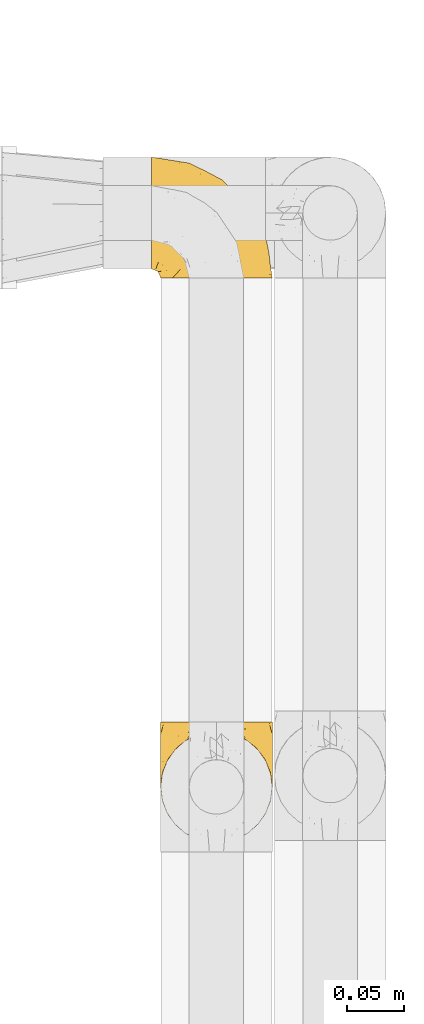
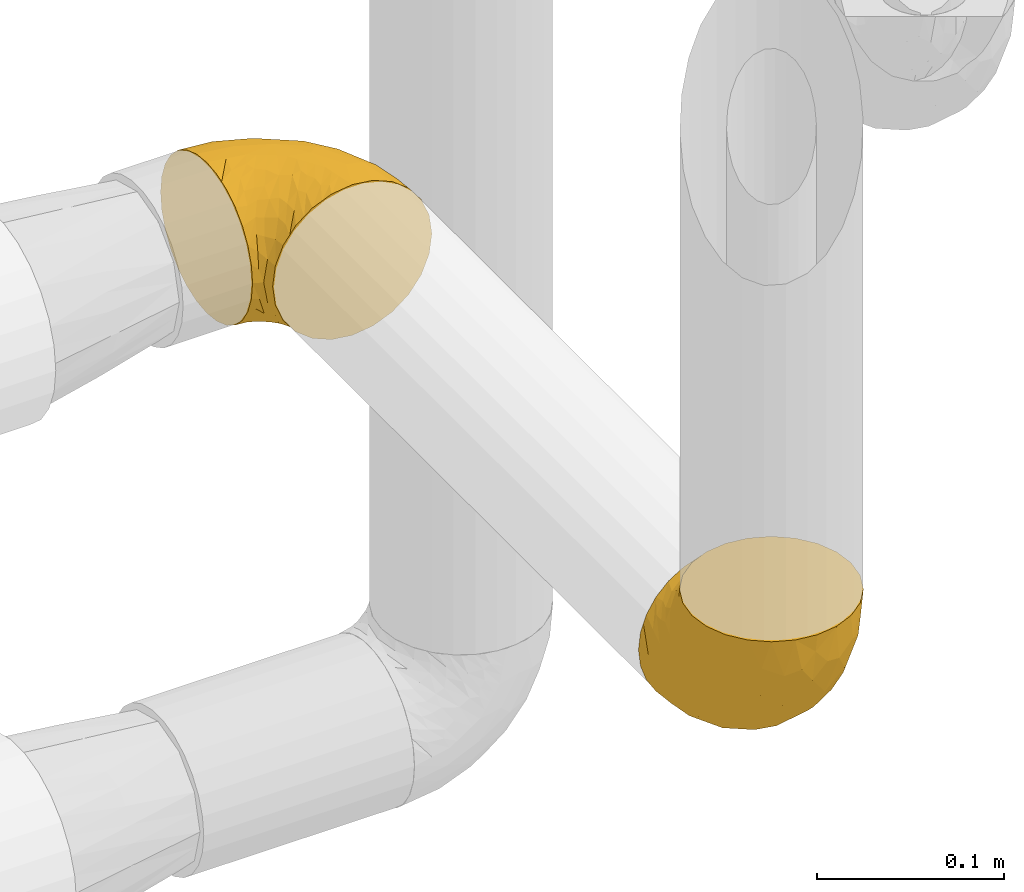
# One storey, part 415 of 827: 2 coverings.
"""IFC2X3 building model written with IfcOpenShell, lengths in millimetres."""

from ifc_helpers import new_model, entity, si_unit, converted_unit, derived_unit, direction, frame, origin, place, context, subcontext, project, spatial, faceted_brep, element, save


model = new_model("IFC2X3")

# Units and contexts
model_context = context("Model", 3, precision=0.01, world=origin(), true_north=direction((6.12303176911189e-17, 1.0)))
body_context = subcontext(model_context, "Body", "Model", "MODEL_VIEW")
ifc_project = project(units=[si_unit("LENGTHUNIT", "METRE", prefix="MILLI"), si_unit("AREAUNIT", "SQUARE_METRE"), si_unit("VOLUMEUNIT", "CUBIC_METRE"), converted_unit("PLANEANGLEUNIT", "DEGREE", entity("IfcRatioMeasure", 0.0174532925199433), si_unit("PLANEANGLEUNIT", "RADIAN"), dimensions=[0, 0, 0, 0, 0, 0, 0]), si_unit("MASSUNIT", "GRAM", prefix="KILO"), derived_unit("MASSDENSITYUNIT", [(si_unit("MASSUNIT", "GRAM", prefix="KILO"), 1), (si_unit("LENGTHUNIT", "METRE"), -3)]), derived_unit("MOMENTOFINERTIAUNIT", [(si_unit("LENGTHUNIT", "METRE"), 4)]), si_unit("TIMEUNIT", "SECOND"), si_unit("FREQUENCYUNIT", "HERTZ"), si_unit("THERMODYNAMICTEMPERATUREUNIT", "DEGREE_CELSIUS"), derived_unit("THERMALTRANSMITTANCEUNIT", [(si_unit("MASSUNIT", "GRAM", prefix="KILO"), 1), (si_unit("THERMODYNAMICTEMPERATUREUNIT", "KELVIN"), -1), (si_unit("TIMEUNIT", "SECOND"), -3)]), derived_unit("VOLUMETRICFLOWRATEUNIT", [(si_unit("LENGTHUNIT", "METRE"), 3), (si_unit("TIMEUNIT", "SECOND"), -1)]), derived_unit("MASSFLOWRATEUNIT", [(si_unit("MASSUNIT", "GRAM", prefix="KILO"), 1), (si_unit("TIMEUNIT", "SECOND"), -1)]), derived_unit("ROTATIONALFREQUENCYUNIT", [(si_unit("TIMEUNIT", "SECOND"), -1)]), si_unit("ELECTRICCURRENTUNIT", "AMPERE"), si_unit("ELECTRICVOLTAGEUNIT", "VOLT"), si_unit("POWERUNIT", "WATT"), si_unit("FORCEUNIT", "NEWTON", prefix="KILO"), si_unit("ILLUMINANCEUNIT", "LUX"), si_unit("LUMINOUSFLUXUNIT", "LUMEN"), si_unit("LUMINOUSINTENSITYUNIT", "CANDELA"), derived_unit("USERDEFINED", [(si_unit("MASSUNIT", "GRAM", prefix="KILO"), -1), (si_unit("LENGTHUNIT", "METRE"), -2), (si_unit("TIMEUNIT", "SECOND"), 3), (si_unit("LUMINOUSFLUXUNIT", "LUMEN"), 1)]), derived_unit("LINEARVELOCITYUNIT", [(si_unit("LENGTHUNIT", "METRE"), 1), (si_unit("TIMEUNIT", "SECOND"), -1)]), si_unit("PRESSUREUNIT", "PASCAL"), derived_unit("USERDEFINED", [(si_unit("LENGTHUNIT", "METRE"), -2), (si_unit("MASSUNIT", "GRAM", prefix="KILO"), 1), (si_unit("TIMEUNIT", "SECOND"), -2)]), derived_unit("LINEARFORCEUNIT", [(si_unit("MASSUNIT", "GRAM", prefix="KILO"), 1), (si_unit("LENGTHUNIT", "METRE"), 1), (si_unit("TIMEUNIT", "SECOND"), -2), (si_unit("LENGTHUNIT", "METRE"), -1)]), derived_unit("PLANARFORCEUNIT", [(si_unit("MASSUNIT", "GRAM", prefix="KILO"), 1), (si_unit("LENGTHUNIT", "METRE"), 1), (si_unit("TIMEUNIT", "SECOND"), -2), (si_unit("LENGTHUNIT", "METRE"), -2)])], contexts=[model_context])

# Site, building, storey
site_placement = place(None, origin())
site = spatial("IfcSite", under=ifc_project, at=site_placement, CompositionType="ELEMENT")
building_placement = place(site_placement, origin())
building = spatial("IfcBuilding", under=site, at=building_placement, CompositionType="ELEMENT")
storey_placement = place(building_placement, frame((0.0, 0.0, 28200.0)))
storey = spatial("IfcBuildingStorey", under=building, at=storey_placement, Name="08", CompositionType="ELEMENT", Elevation=28200.0)

# Coverings
covering_1_placement = place(storey_placement, frame((50221.29, 18589.78, 1599.25)))
element("IfcCovering", 1, at=covering_1_placement, inside=storey, Name=":ADSK_", ObjectType=":ADSK_", PredefinedType="INSULATION", context=body_context, shape_type="Brep", body=[
    faceted_brep([(99.9, 107.75, 50.75), (98.66, 107.75, 39.8), (95.02, 107.75, 29.41), (89.17, 107.75, 20.09), (81.38, 107.75, 12.31), (72.06, 107.75, 6.46), (61.68, 107.75, 2.83), (50.75, 107.75, 1.6), (39.8, 107.75, 2.83), (29.41, 107.75, 6.47), (20.09, 107.75, 12.32), (12.31, 107.75, 20.11), (6.46, 107.75, 29.43), (2.83, 107.75, 39.81), (1.6, 107.75, 50.75), (2.24, 107.75, 56.45), (2.83, 107.75, 61.69), (4.65, 107.75, 66.88), (6.47, 107.75, 72.08), (12.32, 107.75, 81.4), (20.11, 107.75, 89.18), (29.43, 107.75, 95.03), (39.81, 107.75, 98.66), (50.75, 107.75, 99.9), (61.69, 107.75, 98.66), (72.08, 107.75, 95.02), (81.4, 107.75, 89.17), (89.18, 107.75, 81.38), (95.03, 107.75, 72.06), (96.85, 107.75, 66.87), (98.66, 107.75, 61.68), (99.25, 107.75, 56.45), (99.57, 107.75, 53.6), (38.02, 98.22, 107.75), (26.17, 93.31, 107.75), (21.08, 89.4, 107.75), (15.99, 85.5, 107.75), (12.09, 80.41, 107.75), (8.18, 75.32, 107.75), (5.73, 69.39, 107.75), (3.27, 63.47, 107.75), (2.35, 56.48, 107.75), (1.97, 53.61, 107.75), (1.6, 50.75, 107.75), (3.27, 38.02, 107.75), (8.18, 26.17, 107.75), (15.99, 15.99, 107.75), (26.17, 8.18, 107.75), (38.02, 3.27, 107.75), (50.75, 1.6, 107.75), (63.47, 3.27, 107.75), (75.32, 8.18, 107.75), (85.5, 15.99, 107.75), (93.31, 26.17, 107.75), (98.22, 38.02, 107.75), (99.9, 50.75, 107.75), (99.14, 56.48, 107.75), (98.22, 63.47, 107.75), (95.77, 69.39, 107.75), (93.31, 75.32, 107.75), (89.4, 80.41, 107.75), (85.5, 85.5, 107.75), (80.41, 89.4, 107.75), (75.32, 93.31, 107.75), (63.47, 98.22, 107.75), (50.75, 99.9, 107.75), (59.31, 27.53, 39.38), (73.08, 25.32, 49.75), (63.72, 16.29, 57.38), (50.75, 6.79, 74.94), (58.64, 4.51, 85.97), (50.75, 3.51, 95.66), (76.74, 17.47, 67.82), (67.68, 7.6, 83.09), (78.92, 12.27, 89.16), (94.31, 70.89, 37.01), (98.76, 87.17, 43.46), (98.4, 67.3, 51.79), (94.57, 31.65, 85.58), (89.91, 33.58, 62.84), (96.32, 47.23, 62.77), (98.79, 43.26, 88.17), (99.9, 55.08, 85.93), (99.9, 53.99, 91.42), (99.9, 52.9, 96.91), (99.9, 52.36, 99.62), (99.9, 51.82, 102.33), (87.31, 21.5, 82.57), (95.61, 89.94, 32.75), (60.43, 60.45, 13.79), (65.24, 83.0, 6.77), (72.87, 64.79, 16.46), (99.9, 85.93, 55.08), (99.9, 81.31, 58.17), (99.9, 76.69, 61.26), (99.9, 72.06, 64.35), (99.9, 67.44, 67.44), (90.65, 88.74, 24.18), (63.14, 45.98, 23.37), (91.89, 47.13, 49.76), (75.25, 89.4, 9.84), (50.75, 95.66, 3.51), (82.18, 28.5, 55.75), (85.08, 42.81, 42.34), (76.93, 38.28, 37.78), (50.75, 45.35, 21.87), (50.75, 33.61, 33.61), (83.02, 82.57, 17.1), (99.9, 105.04, 51.28), (99.9, 102.33, 51.82), (99.9, 96.91, 52.9), (99.9, 91.42, 53.99), (87.13, 65.92, 28.01), (80.85, 53.11, 28.99), (99.17, 54.37, 69.9), (50.75, 74.94, 6.79), (99.9, 64.35, 72.06), (99.9, 61.26, 76.69), (99.9, 58.17, 81.31), (50.75, 21.87, 45.35), (67.61, 34.79, 34.79), (72.25, 48.48, 25.72), (50.75, 60.15, 14.33), (50.75, 14.33, 60.15), (98.69, 99.07, 62.38), (99.01, 60.55, 100.57), (98.79, 64.18, 91.06), (98.29, 64.36, 97.66), (68.51, 103.17, 97.55), (76.82, 101.69, 93.65), (98.54, 87.75, 66.85), (99.3, 89.38, 61.93), (83.57, 88.34, 101.4), (89.47, 82.14, 100.07), (75.76, 94.51, 101.36), (84.86, 89.64, 95.94), (75.89, 98.41, 96.3), (64.77, 99.71, 101.98), (90.83, 89.37, 85.88), (94.62, 88.21, 78.88), (90.37, 95.2, 82.8), (91.18, 79.14, 102.58), (88.65, 101.22, 82.88), (84.11, 99.41, 88.57), (91.75, 84.72, 88.67), (96.86, 97.47, 69.08), (50.75, 102.19, 102.19), (58.97, 104.02, 100.06), (98.37, 82.66, 70.56), (83.91, 95.42, 91.07), (97.52, 78.67, 77.56), (95.55, 72.69, 96.59), (98.76, 66.46, 86.38), (95.26, 75.3, 91.79), (98.04, 72.74, 81.71), (90.65, 82.93, 94.11), (93.51, 99.27, 76.09), (94.16, 93.51, 76.91), (99.1, 67.35, 81.44), (25.73, 94.51, 101.37), (10.84, 82.94, 94.12), (17.92, 88.33, 101.41), (16.64, 89.64, 95.96), (30.44, 103.62, 96.22), (2.95, 87.74, 66.85), (2.19, 89.38, 61.94), (1.6, 81.31, 58.17), (4.63, 97.47, 69.1), (17.39, 99.41, 88.58), (1.6, 52.9, 96.91), (1.6, 51.82, 102.33), (1.6, 51.28, 105.04), (12.86, 101.21, 82.9), (11.13, 95.19, 82.82), (3.2, 64.36, 97.66), (5.94, 72.69, 96.59), (10.31, 79.14, 102.58), (8.0, 99.28, 76.13), (7.34, 93.51, 76.93), (2.48, 60.55, 100.57), (2.73, 66.46, 86.38), (2.64, 63.96, 90.86), (1.6, 96.91, 52.9), (2.8, 99.06, 62.39), (36.71, 99.7, 101.98), (1.6, 53.99, 91.42), (1.6, 55.08, 85.93), (38.59, 103.3, 99.49), (1.6, 102.33, 51.82), (1.6, 99.62, 52.36), (1.6, 76.69, 61.26), (3.12, 82.66, 70.56), (17.59, 95.42, 91.09), (1.6, 72.06, 64.35), (3.98, 78.68, 77.6), (6.87, 88.2, 78.89), (3.45, 72.75, 81.71), (9.76, 84.74, 88.69), (1.6, 91.42, 53.99), (1.6, 85.93, 55.08), (25.62, 98.41, 96.31), (10.67, 89.37, 85.9), (2.39, 67.35, 81.45), (1.6, 61.26, 76.69), (6.23, 75.3, 91.79), (12.02, 82.13, 100.07), (1.6, 58.17, 81.31), (1.6, 64.35, 72.06), (1.6, 67.44, 67.44), (2.4, 54.08, 69.6), (42.85, 4.51, 85.97), (14.18, 21.5, 82.57), (11.56, 33.43, 63.16), (19.27, 28.5, 55.81), (24.75, 17.47, 67.81), (28.37, 25.36, 49.73), (5.95, 90.18, 32.55), (2.79, 86.97, 43.23), (2.71, 43.26, 88.17), (37.78, 16.29, 57.38), (33.81, 7.6, 83.08), (22.57, 12.27, 89.16), (6.92, 31.65, 85.58), (28.61, 64.79, 16.46), (36.24, 83.0, 6.77), (41.05, 60.44, 13.8), (24.55, 38.35, 37.71), (33.88, 34.8, 34.8), (7.11, 71.54, 36.83), (42.18, 27.53, 39.38), (18.46, 82.57, 17.12), (10.84, 88.74, 24.19), (20.69, 53.19, 28.89), (29.27, 48.49, 25.69), (3.1, 67.28, 51.77), (9.18, 52.32, 45.66), (38.38, 45.94, 23.39), (26.23, 89.4, 9.85), (14.34, 65.75, 28.11), (5.46, 46.73, 62.27), (16.39, 42.82, 42.35)], [[[0, 1, 2, 3, 4, 5, 6, 7, 8, 9, 10, 11, 12, 13, 14, 15, 16, 17, 18, 19, 20, 21, 22, 23, 24, 25, 26, 27, 28, 29, 30, 31, 32]], [[33, 34, 35, 36, 37, 38, 39, 40, 41, 42, 43, 44, 45, 46, 47, 48, 49, 50, 51, 52, 53, 54, 55, 56, 57, 58, 59, 60, 61, 62, 63, 64, 65]], [[66, 67, 68]], [[69, 70, 71]], [[68, 72, 73]], [[73, 72, 74]], [[75, 76, 77]], [[78, 79, 80]], [[51, 50, 73]], [[81, 82, 83, 84, 85, 86, 55]], [[52, 87, 53]], [[74, 52, 51]], [[2, 1, 88]], [[89, 90, 91]], [[77, 92, 93, 94, 95, 96]], [[55, 54, 81]], [[78, 53, 87]], [[5, 90, 6]], [[88, 76, 75]], [[97, 3, 2]], [[89, 91, 98]], [[99, 80, 79]], [[90, 5, 100]], [[74, 87, 52]], [[100, 5, 4]], [[90, 101, 6]], [[79, 102, 103]], [[102, 67, 104]], [[105, 98, 106]], [[107, 4, 3]], [[76, 0, 108, 109, 110, 111, 92]], [[107, 112, 113]], [[114, 77, 96]], [[89, 115, 90]], [[114, 96, 116, 117, 118, 82]], [[75, 97, 88]], [[119, 66, 68]], [[50, 71, 70]], [[100, 91, 90]], [[99, 77, 80]], [[102, 104, 103]], [[97, 107, 3]], [[80, 81, 78]], [[107, 97, 112]], [[68, 73, 70]], [[66, 98, 120]], [[78, 81, 54]], [[114, 81, 80]], [[53, 78, 54]], [[78, 87, 79]], [[102, 87, 72]], [[79, 103, 99]], [[4, 107, 100]], [[91, 100, 107]], [[88, 97, 2]], [[112, 97, 75]], [[99, 112, 75]], [[103, 104, 113]], [[91, 121, 98]], [[89, 105, 122, 115]], [[101, 90, 115]], [[101, 7, 6]], [[88, 1, 76]], [[0, 76, 1]], [[92, 77, 76]], [[73, 74, 51]], [[87, 74, 72]], [[81, 114, 82]], [[77, 114, 80]], [[87, 102, 79]], [[67, 102, 72]], [[68, 67, 72]], [[67, 120, 104]], [[120, 121, 104]], [[104, 121, 113]], [[121, 120, 98]], [[91, 107, 113]], [[91, 113, 121]], [[103, 113, 112]], [[66, 119, 106]], [[105, 89, 98]], [[68, 69, 123, 119]], [[67, 66, 120]], [[98, 66, 106]], [[50, 49, 71]], [[50, 70, 73]], [[112, 99, 103]], [[77, 99, 75]], [[69, 68, 70]], [[29, 124, 110]], [[84, 83, 125]], [[126, 82, 118]], [[59, 58, 127]], [[25, 128, 129]], [[130, 93, 131]], [[132, 62, 133]], [[134, 135, 136]], [[137, 65, 64]], [[64, 134, 137]], [[138, 139, 140]], [[111, 110, 124, 92]], [[134, 136, 137]], [[134, 64, 63]], [[133, 61, 141]], [[125, 58, 57]], [[142, 143, 140]], [[142, 26, 143]], [[127, 83, 82]], [[28, 124, 29]], [[108, 0, 32, 31, 30, 110, 109]], [[30, 29, 110]], [[135, 144, 138]], [[28, 145, 124]], [[57, 56, 55, 86, 85, 84]], [[146, 147, 23]], [[24, 23, 147]], [[25, 143, 26]], [[95, 94, 148]], [[24, 128, 25]], [[149, 138, 143]], [[124, 145, 131]], [[127, 58, 125]], [[150, 148, 139]], [[127, 126, 151]], [[151, 59, 127]], [[152, 151, 126]], [[153, 154, 155]], [[153, 133, 141]], [[145, 28, 27]], [[142, 156, 27]], [[157, 148, 130]], [[61, 133, 62]], [[134, 132, 135]], [[147, 128, 24]], [[65, 137, 146]], [[146, 137, 147]], [[128, 137, 136]], [[137, 128, 147]], [[128, 136, 129]], [[149, 129, 136]], [[25, 129, 143]], [[158, 152, 117]], [[152, 118, 117]], [[153, 151, 152]], [[158, 116, 154]], [[144, 150, 138]], [[153, 152, 158]], [[133, 153, 155]], [[133, 155, 132]], [[141, 61, 60]], [[135, 132, 155]], [[134, 63, 132]], [[144, 135, 155]], [[135, 138, 149]], [[155, 154, 144]], [[150, 154, 96]], [[154, 150, 144]], [[148, 94, 130]], [[82, 126, 127]], [[118, 152, 126]], [[150, 96, 95]], [[139, 148, 157]], [[150, 95, 148]], [[93, 92, 131]], [[130, 145, 156]], [[130, 94, 93]], [[84, 125, 57]], [[127, 125, 83]], [[140, 139, 157]], [[150, 139, 138]], [[140, 157, 142]], [[138, 140, 143]], [[156, 142, 157]], [[27, 26, 142]], [[130, 156, 157]], [[145, 27, 156]], [[132, 63, 62]], [[124, 131, 92]], [[130, 131, 145]], [[129, 149, 143]], [[135, 149, 136]], [[60, 151, 141]], [[59, 151, 60]], [[141, 151, 153]], [[116, 96, 154]], [[153, 158, 154]], [[158, 117, 116]], [[34, 33, 159]], [[160, 161, 162]], [[22, 21, 163]], [[164, 165, 166]], [[19, 18, 167]], [[168, 21, 20]], [[42, 41, 40, 169, 170, 171, 43]], [[172, 173, 168]], [[174, 38, 175]], [[176, 37, 36]], [[177, 164, 178]], [[40, 179, 169]], [[180, 181, 175]], [[17, 182, 183]], [[65, 146, 184]], [[185, 174, 186]], [[23, 22, 187]], [[174, 39, 38]], [[15, 14, 188, 189, 182, 16]], [[179, 40, 39]], [[190, 191, 164]], [[192, 163, 168]], [[33, 184, 159]], [[178, 173, 172]], [[193, 194, 191]], [[18, 183, 167]], [[173, 178, 195]], [[196, 197, 194]], [[198, 199, 183, 182]], [[182, 17, 16]], [[18, 17, 183]], [[200, 159, 184]], [[192, 168, 201]], [[187, 163, 200]], [[202, 203, 180]], [[185, 179, 174]], [[160, 204, 205]], [[206, 181, 180]], [[206, 180, 203]], [[199, 165, 183]], [[165, 164, 167]], [[172, 177, 178]], [[200, 192, 162]], [[205, 161, 160]], [[65, 184, 33]], [[163, 187, 22]], [[175, 204, 180]], [[174, 181, 186]], [[204, 196, 202]], [[197, 160, 162]], [[196, 207, 202]], [[205, 204, 176]], [[196, 204, 160]], [[176, 204, 175]], [[205, 35, 161]], [[34, 159, 161]], [[162, 161, 159]], [[200, 162, 159]], [[197, 162, 201]], [[194, 197, 201]], [[196, 160, 197]], [[191, 195, 178]], [[208, 196, 194]], [[186, 181, 206]], [[175, 181, 174]], [[191, 190, 193]], [[193, 208, 194]], [[195, 194, 201]], [[178, 164, 191]], [[168, 163, 21]], [[166, 165, 199]], [[166, 190, 164]], [[187, 200, 184]], [[184, 146, 187]], [[23, 187, 146]], [[174, 179, 39]], [[169, 179, 185]], [[194, 195, 191]], [[173, 201, 168]], [[201, 173, 195]], [[172, 168, 20]], [[20, 19, 172]], [[177, 172, 19]], [[19, 167, 177]], [[164, 177, 167]], [[35, 205, 36]], [[35, 34, 161]], [[183, 165, 167]], [[162, 192, 201]], [[163, 192, 200]], [[175, 38, 37]], [[205, 176, 36]], [[175, 37, 176]], [[204, 202, 180]], [[207, 196, 208]], [[207, 203, 202]], [[209, 186, 206, 203, 207, 208]], [[48, 210, 71]], [[211, 212, 213]], [[214, 213, 215]], [[216, 217, 13]], [[218, 43, 171, 170, 169, 185, 186]], [[219, 220, 214]], [[47, 46, 221]], [[210, 48, 220]], [[211, 222, 212]], [[222, 45, 44]], [[221, 220, 47]], [[47, 220, 48]], [[221, 211, 214]], [[223, 224, 225]], [[211, 46, 45]], [[226, 227, 215]], [[43, 218, 44]], [[217, 216, 228]], [[219, 215, 229]], [[14, 13, 217]], [[224, 9, 8]], [[10, 230, 11]], [[11, 231, 12]], [[232, 223, 233]], [[234, 208, 193, 190, 166, 199]], [[235, 234, 228]], [[222, 44, 218]], [[106, 229, 236]], [[224, 237, 9]], [[231, 238, 228]], [[9, 237, 10]], [[115, 224, 101]], [[239, 234, 235]], [[231, 11, 230]], [[223, 230, 237]], [[224, 8, 101]], [[223, 236, 233]], [[225, 115, 122, 105]], [[216, 12, 231]], [[209, 234, 239]], [[210, 219, 69]], [[219, 214, 215]], [[229, 119, 219]], [[209, 218, 186]], [[239, 212, 222]], [[239, 222, 218]], [[45, 222, 211]], [[235, 212, 239]], [[213, 212, 240]], [[223, 237, 224]], [[230, 10, 237]], [[238, 231, 230]], [[216, 231, 228]], [[232, 230, 223]], [[235, 238, 240]], [[115, 225, 224]], [[233, 236, 227]], [[8, 7, 101]], [[234, 209, 208]], [[218, 209, 239]], [[217, 228, 234]], [[13, 12, 216]], [[234, 199, 217]], [[217, 199, 198, 182, 189, 188, 14]], [[211, 221, 46]], [[220, 221, 214]], [[71, 210, 69]], [[71, 49, 48]], [[219, 210, 220]], [[226, 215, 213]], [[211, 213, 214]], [[226, 213, 240]], [[215, 227, 229]], [[232, 240, 238]], [[233, 227, 226]], [[232, 233, 226]], [[236, 223, 225]], [[240, 232, 226]], [[232, 238, 230]], [[225, 105, 236]], [[236, 105, 106]], [[236, 229, 227]], [[123, 69, 219, 119]], [[106, 119, 229]], [[238, 235, 228]], [[212, 235, 240]]]),
])
covering_2_placement = place(storey_placement, frame((50213.44, 19086.93, 1599.25)))
element("IfcCovering", 2, at=covering_2_placement, inside=storey, Name=":ADSK_", ObjectType=":ADSK_", PredefinedType="INSULATION", context=body_context, shape_type="Brep", body=[
    faceted_brep([(1.6, 58.6, 99.9), (1.6, 69.54, 98.66), (1.6, 79.93, 95.02), (1.6, 89.25, 89.17), (1.6, 97.03, 81.38), (1.6, 102.88, 72.06), (1.6, 106.51, 61.68), (1.6, 107.75, 50.75), (1.6, 106.51, 39.8), (1.6, 102.87, 29.41), (1.6, 97.02, 20.09), (1.6, 89.23, 12.31), (1.6, 79.91, 6.46), (1.6, 69.53, 2.83), (1.6, 58.6, 1.6), (1.6, 52.89, 2.24), (1.6, 47.65, 2.83), (1.6, 42.46, 4.65), (1.6, 37.26, 6.47), (1.6, 27.94, 12.32), (1.6, 20.16, 20.11), (1.6, 14.31, 29.43), (1.6, 10.68, 39.81), (1.6, 9.45, 50.75), (1.6, 10.68, 61.69), (1.6, 14.32, 72.08), (1.6, 20.17, 81.4), (1.6, 27.96, 89.18), (1.6, 37.28, 95.03), (1.6, 42.47, 96.85), (1.6, 47.66, 98.66), (1.6, 52.89, 99.25), (1.6, 55.75, 99.57), (11.12, 1.6, 38.02), (16.03, 1.6, 26.17), (19.94, 1.6, 21.08), (23.84, 1.6, 15.99), (28.93, 1.6, 12.09), (34.02, 1.6, 8.18), (39.95, 1.6, 5.73), (45.87, 1.6, 3.27), (52.86, 1.6, 2.35), (55.73, 1.6, 1.97), (58.6, 1.6, 1.6), (71.32, 1.6, 3.27), (83.17, 1.6, 8.18), (93.35, 1.6, 15.99), (101.16, 1.6, 26.17), (106.07, 1.6, 38.02), (107.75, 1.6, 50.75), (106.07, 1.6, 63.47), (101.16, 1.6, 75.32), (93.35, 1.6, 85.5), (83.17, 1.6, 93.31), (71.32, 1.6, 98.22), (58.6, 1.6, 99.9), (52.86, 1.6, 99.14), (45.87, 1.6, 98.22), (39.95, 1.6, 95.77), (34.02, 1.6, 93.31), (28.93, 1.6, 89.4), (23.84, 1.6, 85.5), (19.94, 1.6, 80.41), (16.03, 1.6, 75.32), (11.12, 1.6, 63.47), (9.45, 1.6, 50.75), (81.82, 69.96, 59.31), (84.02, 59.59, 73.08), (93.05, 51.96, 63.72), (102.55, 34.4, 50.75), (104.83, 23.37, 58.64), (105.83, 13.68, 50.75), (91.87, 41.52, 76.74), (101.74, 26.26, 67.68), (97.07, 20.18, 78.92), (38.45, 72.33, 94.31), (22.17, 65.88, 98.76), (42.04, 57.55, 98.4), (77.69, 23.76, 94.57), (75.76, 46.5, 89.91), (62.11, 46.57, 96.32), (66.08, 21.17, 98.79), (54.26, 23.41, 99.9), (55.35, 17.92, 99.9), (56.44, 12.43, 99.9), (56.98, 9.72, 99.9), (57.52, 7.01, 99.9), (87.84, 26.77, 87.31), (19.41, 76.59, 95.61), (48.89, 95.55, 60.43), (26.34, 102.57, 65.24), (44.55, 92.89, 72.87), (23.41, 54.26, 99.9), (28.03, 51.17, 99.9), (32.65, 48.08, 99.9), (37.28, 44.99, 99.9), (41.9, 41.9, 99.9), (20.6, 85.16, 90.65), (63.36, 85.97, 63.14), (62.21, 59.58, 91.89), (19.94, 99.5, 75.25), (13.68, 105.83, 50.75), (80.85, 53.59, 82.18), (66.53, 67.0, 85.08), (71.06, 71.56, 76.93), (63.99, 87.47, 50.75), (75.73, 75.73, 50.75), (26.77, 92.24, 83.02), (4.31, 58.06, 99.9), (7.01, 57.52, 99.9), (12.43, 56.44, 99.9), (17.92, 55.35, 99.9), (43.43, 81.33, 87.13), (56.23, 80.35, 80.85), (54.97, 39.44, 99.17), (34.4, 102.55, 50.75), (44.99, 37.28, 99.9), (48.08, 32.65, 99.9), (51.17, 28.03, 99.9), (87.47, 63.99, 50.75), (74.55, 74.55, 67.61), (60.86, 83.62, 72.25), (49.19, 95.01, 50.75), (95.01, 49.19, 50.75), (10.27, 46.96, 98.69), (48.79, 8.77, 99.01), (45.16, 18.28, 98.79), (44.99, 11.68, 98.29), (6.17, 11.79, 68.51), (7.65, 15.69, 76.82), (21.59, 42.49, 98.54), (19.96, 47.41, 99.3), (21.0, 7.94, 83.57), (27.2, 9.27, 89.47), (14.83, 7.98, 75.76), (19.7, 13.4, 84.86), (10.93, 13.04, 75.89), (9.63, 7.36, 64.77), (19.97, 23.46, 90.83), (21.13, 30.46, 94.62), (14.14, 26.54, 90.37), (30.2, 6.76, 91.18), (36.65, 12.75, 95.55), (8.12, 26.46, 88.65), (9.93, 20.77, 84.11), (24.62, 20.68, 91.75), (11.87, 40.26, 96.86), (7.15, 7.15, 50.75), (5.32, 9.28, 58.97), (26.68, 38.78, 98.37), (13.92, 18.27, 83.91), (30.67, 31.78, 97.52), (42.89, 22.96, 98.76), (34.04, 17.55, 95.26), (36.6, 27.63, 98.04), (26.41, 15.23, 90.65), (10.07, 33.25, 93.51), (15.83, 32.43, 94.16), (41.99, 27.9, 99.1), (14.83, 7.97, 25.73), (26.4, 15.22, 10.84), (21.01, 7.93, 17.92), (19.71, 13.38, 16.64), (5.72, 13.12, 30.44), (21.6, 42.49, 2.95), (19.96, 47.4, 2.19), (28.03, 51.17, 1.6), (11.87, 40.24, 4.63), (9.93, 20.76, 17.39), (56.44, 12.43, 1.6), (57.52, 7.01, 1.6), (58.06, 4.31, 1.6), (8.13, 26.44, 12.86), (14.15, 26.52, 11.13), (44.99, 11.68, 3.2), (36.65, 12.75, 5.94), (27.21, 9.27, 12.02), (34.04, 17.55, 6.23), (30.2, 6.76, 10.31), (10.06, 33.21, 8.0), (15.83, 32.41, 7.34), (48.79, 8.77, 2.48), (42.89, 22.96, 2.73), (45.38, 18.48, 2.64), (12.43, 56.44, 1.6), (10.28, 46.95, 2.8), (9.64, 7.36, 36.71), (55.35, 17.92, 1.6), (54.26, 23.41, 1.6), (6.05, 9.85, 38.59), (7.01, 57.52, 1.6), (9.72, 56.98, 1.6), (32.65, 48.08, 1.6), (26.68, 38.78, 3.12), (13.92, 18.25, 17.59), (37.28, 44.99, 1.6), (30.66, 31.74, 3.98), (21.14, 30.45, 6.87), (36.59, 27.63, 3.45), (24.6, 20.65, 9.76), (17.92, 55.35, 1.6), (23.41, 54.26, 1.6), (10.93, 13.03, 25.62), (19.97, 23.44, 10.67), (41.99, 27.9, 2.39), (48.08, 32.65, 1.6), (51.17, 28.03, 1.6), (44.99, 37.28, 1.6), (41.9, 41.9, 1.6), (55.26, 39.74, 2.4), (104.83, 23.37, 42.85), (87.84, 26.77, 14.18), (75.91, 46.18, 11.56), (80.84, 53.54, 19.27), (91.87, 41.53, 24.75), (83.98, 59.61, 28.37), (19.16, 76.79, 5.95), (22.37, 66.11, 2.79), (66.08, 21.17, 2.71), (93.05, 51.96, 37.78), (101.74, 26.26, 33.81), (97.07, 20.18, 22.57), (77.69, 23.76, 6.92), (44.55, 92.88, 28.61), (26.34, 102.57, 36.24), (48.9, 95.54, 41.05), (70.99, 71.63, 24.55), (74.55, 74.55, 33.88), (37.8, 72.51, 7.11), (63.4, 85.95, 38.38), (81.82, 69.96, 42.18), (26.77, 92.23, 18.46), (20.6, 85.15, 10.84), (56.15, 80.45, 20.69), (60.85, 83.65, 29.27), (42.06, 57.57, 3.1), (57.03, 63.68, 9.18), (19.94, 99.49, 26.23), (43.59, 81.23, 14.34), (62.61, 47.07, 5.46), (66.52, 66.99, 16.39)], [[[0, 1, 2, 3, 4, 5, 6, 7, 8, 9, 10, 11, 12, 13, 14, 15, 16, 17, 18, 19, 20, 21, 22, 23, 24, 25, 26, 27, 28, 29, 30, 31, 32]], [[33, 34, 35, 36, 37, 38, 39, 40, 41, 42, 43, 44, 45, 46, 47, 48, 49, 50, 51, 52, 53, 54, 55, 56, 57, 58, 59, 60, 61, 62, 63, 64, 65]], [[66, 67, 68]], [[69, 70, 71]], [[68, 72, 73]], [[73, 72, 74]], [[75, 76, 77]], [[78, 79, 80]], [[51, 50, 73]], [[81, 82, 83, 84, 85, 86, 55]], [[52, 87, 53]], [[74, 52, 51]], [[2, 1, 88]], [[89, 90, 91]], [[77, 92, 93, 94, 95, 96]], [[55, 54, 81]], [[78, 53, 87]], [[5, 90, 6]], [[88, 76, 75]], [[97, 3, 2]], [[89, 91, 98]], [[99, 80, 79]], [[90, 5, 100]], [[74, 87, 52]], [[100, 5, 4]], [[90, 101, 6]], [[79, 102, 103]], [[102, 67, 104]], [[105, 98, 106]], [[107, 4, 3]], [[76, 0, 108, 109, 110, 111, 92]], [[107, 112, 113]], [[114, 77, 96]], [[89, 115, 90]], [[114, 96, 116, 117, 118, 82]], [[75, 97, 88]], [[119, 66, 68]], [[50, 71, 70]], [[100, 91, 90]], [[99, 77, 80]], [[102, 104, 103]], [[97, 107, 3]], [[80, 81, 78]], [[107, 97, 112]], [[68, 73, 70]], [[66, 98, 120]], [[78, 81, 54]], [[114, 81, 80]], [[53, 78, 54]], [[78, 87, 79]], [[102, 87, 72]], [[79, 103, 99]], [[4, 107, 100]], [[91, 100, 107]], [[88, 97, 2]], [[112, 97, 75]], [[99, 112, 75]], [[103, 104, 113]], [[91, 121, 98]], [[89, 105, 122, 115]], [[101, 90, 115]], [[101, 7, 6]], [[88, 1, 76]], [[0, 76, 1]], [[92, 77, 76]], [[73, 74, 51]], [[87, 74, 72]], [[81, 114, 82]], [[77, 114, 80]], [[87, 102, 79]], [[67, 102, 72]], [[68, 67, 72]], [[67, 120, 104]], [[120, 121, 104]], [[104, 121, 113]], [[121, 120, 98]], [[91, 107, 113]], [[91, 113, 121]], [[103, 113, 112]], [[106, 98, 66]], [[105, 89, 98]], [[106, 66, 119]], [[67, 66, 120]], [[68, 69, 123, 119]], [[50, 49, 71]], [[50, 70, 73]], [[112, 99, 103]], [[77, 99, 75]], [[69, 68, 70]], [[29, 124, 110]], [[84, 83, 125]], [[126, 82, 118]], [[59, 58, 127]], [[25, 128, 129]], [[130, 93, 131]], [[132, 62, 133]], [[134, 135, 136]], [[137, 65, 64]], [[64, 134, 137]], [[138, 139, 140]], [[111, 110, 124, 92]], [[134, 136, 137]], [[134, 64, 63]], [[141, 60, 142]], [[125, 58, 57]], [[143, 144, 140]], [[143, 26, 144]], [[127, 83, 82]], [[28, 124, 29]], [[108, 0, 32, 31, 30, 110, 109]], [[30, 29, 110]], [[135, 145, 138]], [[28, 146, 124]], [[57, 56, 55, 86, 85, 84]], [[147, 148, 23]], [[24, 23, 148]], [[25, 144, 26]], [[95, 94, 149]], [[24, 128, 25]], [[150, 138, 144]], [[124, 146, 131]], [[127, 58, 125]], [[151, 149, 139]], [[127, 126, 142]], [[142, 59, 127]], [[152, 142, 126]], [[153, 154, 155]], [[153, 133, 141]], [[146, 28, 27]], [[143, 156, 27]], [[157, 149, 130]], [[61, 133, 62]], [[134, 132, 135]], [[148, 128, 24]], [[65, 137, 147]], [[147, 137, 148]], [[128, 137, 136]], [[137, 128, 148]], [[128, 136, 129]], [[150, 129, 136]], [[25, 129, 144]], [[158, 152, 117]], [[152, 118, 117]], [[153, 142, 152]], [[158, 116, 154]], [[145, 151, 138]], [[153, 152, 158]], [[133, 153, 155]], [[133, 155, 132]], [[153, 141, 142]], [[135, 132, 155]], [[134, 63, 132]], [[145, 135, 155]], [[135, 138, 150]], [[155, 154, 145]], [[151, 154, 96]], [[154, 151, 145]], [[149, 94, 130]], [[82, 126, 127]], [[118, 152, 126]], [[151, 96, 95]], [[139, 149, 157]], [[151, 95, 149]], [[93, 92, 131]], [[130, 146, 156]], [[130, 94, 93]], [[84, 125, 57]], [[127, 125, 83]], [[140, 139, 157]], [[151, 139, 138]], [[140, 157, 143]], [[138, 140, 144]], [[156, 143, 157]], [[27, 26, 143]], [[130, 156, 157]], [[146, 27, 156]], [[132, 63, 62]], [[124, 131, 92]], [[130, 131, 146]], [[129, 150, 144]], [[135, 150, 136]], [[60, 141, 61]], [[60, 59, 142]], [[133, 61, 141]], [[116, 96, 154]], [[153, 158, 154]], [[158, 117, 116]], [[34, 33, 159]], [[160, 161, 162]], [[22, 21, 163]], [[164, 165, 166]], [[19, 18, 167]], [[168, 21, 20]], [[42, 41, 40, 169, 170, 171, 43]], [[172, 173, 168]], [[174, 38, 175]], [[176, 177, 178]], [[179, 164, 180]], [[40, 181, 169]], [[182, 183, 175]], [[17, 184, 185]], [[65, 147, 186]], [[187, 174, 188]], [[23, 22, 189]], [[174, 39, 38]], [[15, 14, 190, 191, 184, 16]], [[181, 40, 39]], [[192, 193, 164]], [[194, 163, 168]], [[33, 186, 159]], [[180, 173, 172]], [[195, 196, 193]], [[18, 185, 167]], [[173, 180, 197]], [[198, 199, 196]], [[200, 201, 185, 184]], [[184, 17, 16]], [[18, 17, 185]], [[202, 159, 186]], [[194, 168, 203]], [[189, 163, 202]], [[204, 205, 182]], [[187, 181, 174]], [[160, 177, 176]], [[206, 183, 182]], [[206, 182, 205]], [[201, 165, 185]], [[165, 164, 167]], [[172, 179, 180]], [[202, 194, 162]], [[176, 161, 160]], [[65, 186, 33]], [[163, 189, 22]], [[175, 177, 182]], [[174, 183, 188]], [[177, 198, 204]], [[199, 160, 162]], [[198, 207, 204]], [[175, 38, 37]], [[198, 177, 160]], [[178, 177, 175]], [[176, 35, 161]], [[34, 159, 161]], [[162, 161, 159]], [[202, 162, 159]], [[199, 162, 203]], [[196, 199, 203]], [[198, 160, 199]], [[193, 197, 180]], [[208, 198, 196]], [[188, 183, 206]], [[175, 183, 174]], [[193, 192, 195]], [[195, 208, 196]], [[197, 196, 203]], [[180, 164, 193]], [[168, 163, 21]], [[166, 165, 201]], [[166, 192, 164]], [[189, 202, 186]], [[186, 147, 189]], [[23, 189, 147]], [[174, 181, 39]], [[169, 181, 187]], [[196, 197, 193]], [[173, 203, 168]], [[203, 173, 197]], [[172, 168, 20]], [[20, 19, 172]], [[179, 172, 19]], [[19, 167, 179]], [[164, 179, 167]], [[35, 176, 36]], [[35, 34, 161]], [[185, 165, 167]], [[162, 194, 203]], [[163, 194, 202]], [[176, 178, 36]], [[37, 36, 178]], [[175, 37, 178]], [[177, 204, 182]], [[207, 198, 208]], [[207, 205, 204]], [[209, 188, 206, 205, 207, 208]], [[48, 210, 71]], [[211, 212, 213]], [[214, 213, 215]], [[216, 217, 13]], [[218, 43, 171, 170, 169, 187, 188]], [[219, 220, 214]], [[47, 46, 221]], [[210, 48, 220]], [[211, 222, 212]], [[222, 45, 44]], [[221, 220, 47]], [[47, 220, 48]], [[221, 211, 214]], [[223, 224, 225]], [[211, 46, 45]], [[226, 227, 215]], [[43, 218, 44]], [[217, 216, 228]], [[227, 229, 230]], [[14, 13, 217]], [[224, 9, 8]], [[10, 231, 11]], [[11, 232, 12]], [[233, 223, 234]], [[235, 208, 195, 192, 166, 201]], [[236, 235, 228]], [[222, 44, 218]], [[106, 230, 229]], [[224, 237, 9]], [[232, 238, 228]], [[9, 237, 10]], [[115, 224, 101]], [[239, 235, 236]], [[232, 11, 231]], [[223, 231, 237]], [[224, 8, 101]], [[223, 229, 234]], [[225, 115, 122, 105]], [[216, 12, 232]], [[209, 235, 239]], [[210, 219, 69]], [[219, 214, 215]], [[230, 119, 219]], [[209, 218, 188]], [[239, 212, 222]], [[239, 222, 218]], [[45, 222, 211]], [[236, 212, 239]], [[213, 212, 240]], [[223, 237, 224]], [[231, 10, 237]], [[238, 232, 231]], [[216, 232, 228]], [[233, 231, 223]], [[236, 238, 240]], [[115, 225, 224]], [[234, 229, 227]], [[8, 7, 101]], [[235, 209, 208]], [[218, 209, 239]], [[217, 228, 235]], [[13, 12, 216]], [[235, 201, 217]], [[217, 201, 200, 184, 191, 190, 14]], [[211, 221, 46]], [[220, 221, 214]], [[71, 210, 69]], [[71, 49, 48]], [[219, 210, 220]], [[226, 215, 213]], [[211, 213, 214]], [[226, 213, 240]], [[215, 227, 230]], [[233, 240, 238]], [[234, 227, 226]], [[233, 234, 226]], [[229, 223, 225]], [[240, 233, 226]], [[233, 238, 231]], [[225, 105, 229]], [[229, 105, 106]], [[106, 119, 230]], [[123, 69, 219, 119]], [[215, 230, 219]], [[238, 236, 228]], [[212, 236, 240]]]),
])

save(model, "model.ifc")
